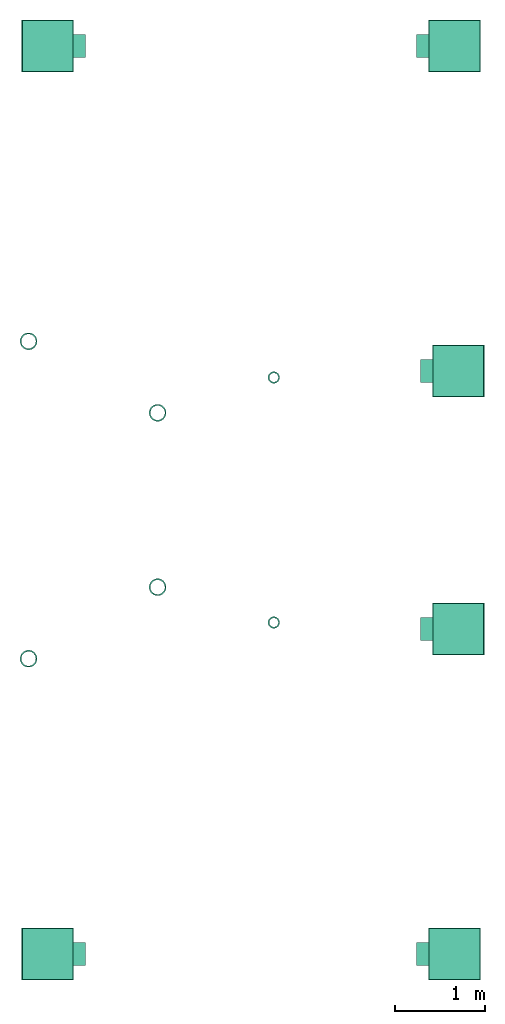
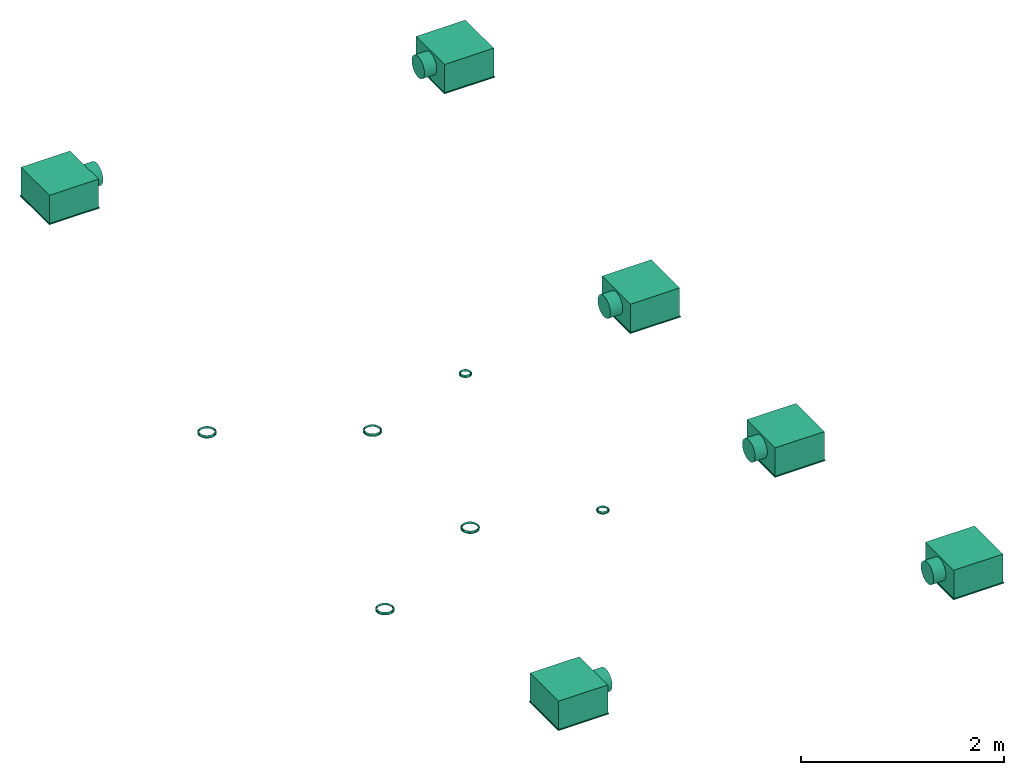
# One storey: 12 flow terminals.
"""IFC2X3 building model written with IfcOpenShell, lengths in millimetres."""

import ifcopenshell
import ifcopenshell.guid

model = None  # the IFC model being written
_history = None  # IfcOwnerHistory: only IFC2X3 demands one
_inside = {}  # id of a spatial element -> (the spatial element, [elements in it])
_under = {}  # id of a project, library or spatial element -> (it, [spatial elements below it])
_declared = {}  # id of a project -> (the project, [libraries it declares])
_typed = {}  # id of a type object -> (the type object, [elements of that type])
_made_of = {}  # id of a material, layer set ... -> (it, [elements and type objects made of it])


def new_model(schema):
    """Start an empty IFC model of exactly this schema.

    Asked for "IFC4X3", IfcOpenShell would pick the latest addendum, in which some entities
    have other attributes; the version numbers below select the first issue.
    IFC2X3 requires an IfcOwnerHistory on every rooted entity: one is made here for all.
    """
    global model, _history
    if schema == "IFC4X3":
        model = ifcopenshell.file(schema_version=(4, 3, 0, 0))
    else:
        model = ifcopenshell.file(schema=schema)
    _inside.clear()
    _under.clear()
    _declared.clear()
    _typed.clear()
    _made_of.clear()
    _history = None
    if model.schema == "IFC2X3":
        org = make("IfcOrganization", Name="unknown")
        user = make(
            "IfcPersonAndOrganization",
            ThePerson=make("IfcPerson", FamilyName="unknown"),
            TheOrganization=org,
        )
        app = make(
            "IfcApplication",
            ApplicationDeveloper=org,
            Version="unknown",
            ApplicationFullName="unknown",
            ApplicationIdentifier="unknown",
        )
        _history = make(
            "IfcOwnerHistory",
            OwningUser=user,
            OwningApplication=app,
            ChangeAction="ADDED",
            CreationDate=0,
        )
    return model


def make(cls, **values):
    """One entity of the class cls with the attributes given. An attribute that is None is left unset."""
    return model.create_entity(
        cls, **{name: value for name, value in values.items() if value is not None}
    )


def entity(cls, *values):
    """Any entity or typed value of the class cls, its attributes in the order of the schema. None: left unset."""
    e = model.create_entity(cls)
    for i, value in enumerate(values):
        if value is not None:
            e[i] = value
    return e


def rooted(cls, **values):
    """An entity with a GlobalId (a new one), such as an element, a storey or a relation."""
    return make(cls, GlobalId=ifcopenshell.guid.new(), OwnerHistory=_history, **values)


def si_unit(unit_type, name, prefix=None):
    """IfcSIUnit, for example si_unit("LENGTHUNIT", "METRE", prefix="MILLI")."""
    return make("IfcSIUnit", UnitType=unit_type, Prefix=prefix, Name=name)


def converted_unit(unit_type, name, factor, base, dimensions=None, offset=None):
    """IfcConversionBasedUnit, such as the inch: factor (a typed value) times the base unit."""
    return make(
        "IfcConversionBasedUnit"
        if offset is None
        else "IfcConversionBasedUnitWithOffset",
        ConversionOffset=offset,
        Dimensions=None
        if dimensions is None
        else entity("IfcDimensionalExponents", *dimensions),
        UnitType=unit_type,
        Name=name,
        ConversionFactor=make(
            "IfcMeasureWithUnit", ValueComponent=factor, UnitComponent=base
        ),
    )


def derived_unit(unit_type, elements):
    """IfcDerivedUnit: a product of units, each with its exponent."""
    return make(
        "IfcDerivedUnit",
        Elements=[
            make("IfcDerivedUnitElement", Unit=unit, Exponent=power)
            for unit, power in elements
        ],
        UnitType=unit_type,
    )


def assignment(units):
    """IfcUnitAssignment: the units of a project."""
    return None if units is None else make("IfcUnitAssignment", Units=units)


def point(xyz):
    """IfcCartesianPoint."""
    return None if xyz is None else make("IfcCartesianPoint", Coordinates=xyz)


def direction(xyz):
    """IfcDirection."""
    return None if xyz is None else make("IfcDirection", DirectionRatios=xyz)


def frame(location, z_axis=None, x_axis=None):
    """IfcAxis2Placement3D, a coordinate frame: its origin and axes. An axis left out is left unset."""
    return make(
        "IfcAxis2Placement3D",
        Location=point(location),
        Axis=direction(z_axis),
        RefDirection=direction(x_axis),
    )


def frame_2d(location, x_axis=None):
    """IfcAxis2Placement2D, a coordinate frame in the plane: its origin and x axis."""
    return make(
        "IfcAxis2Placement2D", Location=point(location), RefDirection=direction(x_axis)
    )


def origin():
    """The frame at (0, 0, 0) with its axes left unset."""
    return frame((0.0, 0.0, 0.0))


def origin_2d_with_axis():
    """The frame at (0, 0) in the plane with the x axis (1, 0) written out."""
    return frame_2d((0.0, 0.0), x_axis=(1.0, 0.0))


def place(relative_to, where):
    """IfcLocalPlacement: puts the frame where relative to a parent placement (None: the world)."""
    return make(
        "IfcLocalPlacement", PlacementRelTo=relative_to, RelativePlacement=where
    )


def context(
    kind, dimensions, precision=None, world=None, true_north=None, identifier=None
):
    """IfcGeometricRepresentationContext, for example the 3D "Model" context."""
    return make(
        "IfcGeometricRepresentationContext",
        ContextIdentifier=identifier,
        ContextType=kind,
        CoordinateSpaceDimension=dimensions,
        Precision=precision,
        WorldCoordinateSystem=world,
        TrueNorth=true_north,
    )


def subcontext(parent, identifier, kind, view, scale=None):
    """IfcGeometricRepresentationSubContext, for example "Body" below "Model"."""
    return make(
        "IfcGeometricRepresentationSubContext",
        ContextIdentifier=identifier,
        ContextType=kind,
        ParentContext=parent,
        TargetScale=scale,
        TargetView=view,
    )


def project(units=None, contexts=None):
    """IfcProject with its units and contexts."""
    return rooted(
        "IfcProject",
        Name="project",
        RepresentationContexts=contexts,
        UnitsInContext=assignment(units),
    )


def spatial(cls, under=None, at=None, **own):
    """A site, building, storey or space (cls), placed at a placement, below another one or the project."""
    s = rooted(cls, ObjectPlacement=at, **own)
    if under is not None:
        _under.setdefault(under.id(), (under, []))[1].append(s)
    return s


def profile(cls, at=None, kind="AREA", **sizes):
    """A parametric profile (cls). Its sizes go by their IFC names, for example OverallWidth=200.0."""
    return make(cls, ProfileType=kind, Position=at, **sizes)


def rectangle(**sizes):
    """IfcRectangleProfileDef."""
    return profile("IfcRectangleProfileDef", **sizes)


def circle(**sizes):
    """IfcCircleProfileDef."""
    return profile("IfcCircleProfileDef", **sizes)


def hollow_circle(**sizes):
    """IfcCircleHollowProfileDef."""
    return profile("IfcCircleHollowProfileDef", **sizes)


def extrude(swept, where, along, depth):
    """IfcExtrudedAreaSolid: the profile swept, set in the frame where, extruded along a direction by depth."""
    return make(
        "IfcExtrudedAreaSolid",
        SweptArea=swept,
        Position=where,
        ExtrudedDirection=direction(along),
        Depth=depth,
    )


def shape(context_of_items, identifier, shape_type, items):
    """IfcShapeRepresentation: the items that make up one representation, for example the "Body"."""
    return make(
        "IfcShapeRepresentation",
        ContextOfItems=context_of_items,
        RepresentationIdentifier=identifier,
        RepresentationType=shape_type,
        Items=items,
    )


def source(mapping_origin, context_of_items, identifier, shape_type, items):
    """IfcRepresentationMap: a shape defined once, which mapped items show again and again."""
    return make(
        "IfcRepresentationMap",
        MappingOrigin=mapping_origin,
        MappedRepresentation=shape(context_of_items, identifier, shape_type, items),
    )


def transform(
    local_origin,
    x_axis=None,
    y_axis=None,
    z_axis=None,
    scale=None,
    scale2=None,
    scale3=None,
    uniform=True,
):
    """IfcCartesianTransformationOperator3D, or its non-uniform kind. x_axis, y_axis, z_axis: its Axis1, 2, 3."""
    if uniform:
        return make(
            "IfcCartesianTransformationOperator3D",
            Axis1=direction(x_axis),
            Axis2=direction(y_axis),
            LocalOrigin=point(local_origin),
            Scale=scale,
            Axis3=direction(z_axis),
        )
    return make(
        "IfcCartesianTransformationOperator3DnonUniform",
        Axis1=direction(x_axis),
        Axis2=direction(y_axis),
        LocalOrigin=point(local_origin),
        Scale=scale,
        Axis3=direction(z_axis),
        Scale2=scale2,
        Scale3=scale3,
    )


def mapped(mapping_source, mapping_target):
    """IfcMappedItem: shows the shape of a source again, moved by a transform."""
    return make(
        "IfcMappedItem", MappingSource=mapping_source, MappingTarget=mapping_target
    )


def made_of(thing, what):
    """Note that an element or type object is made of a material, layer set ...; save() writes the relation."""
    if what is not None:
        _made_of.setdefault(what.id(), (what, []))[1].append(thing)
    return thing


def type_object(cls, material=None, **own):
    """A type object (cls), such as IfcWallType, which elements share."""
    return made_of(rooted(cls, **own), material)


def type_shapes(of_type, sources):
    """Give a type object the sources (RepresentationMaps) that its elements show as mapped items."""
    of_type.RepresentationMaps = sources


def element(
    cls,
    number,
    at=None,
    inside=None,
    cuts=None,
    type_object=None,
    material=None,
    context=None,
    identifier="Body",
    shape_type=None,
    held_by="IfcProductDefinitionShape",
    body=None,
    shapes=None,
    **own,
):
    """One element of the class cls, such as IfcWall. Its Tag is "e" and its number.

    at: its placement. inside: the storey or other place that contains it. cuts: it is an
    opening in that element (IfcRelVoidsElement). A single representation is given by context,
    identifier, shape_type and body (its items); several are given by shapes. held_by: the class
    of the entity that holds the representations. save() writes the other relations.
    """
    e = rooted(cls, Tag="e%d" % number, ObjectPlacement=at, **own)
    if body is not None:
        shapes = [shape(context, identifier, shape_type, body)]
    if shapes is not None:
        e.Representation = make(held_by, Representations=shapes)
    if inside is not None:
        _inside.setdefault(inside.id(), (inside, []))[1].append(e)
    if cuts is not None:
        rooted(
            "IfcRelVoidsElement", RelatingBuildingElement=cuts, RelatedOpeningElement=e
        )
    if type_object is not None:
        _typed.setdefault(type_object.id(), (type_object, []))[1].append(e)
    return made_of(e, material)


def aggregate(whole, parts):
    """IfcRelAggregates: a whole, such as a stair, and the parts it consists of."""
    return rooted("IfcRelAggregates", RelatingObject=whole, RelatedObjects=parts)


def save(model, path):
    """Write the relations noted so far, then the file.

    IfcRelAggregates (storeys below a building ...), IfcRelContainedInSpatialStructure (elements
    in a storey), IfcRelDefinesByType, IfcRelAssociatesMaterial and IfcRelDeclares: one each for
    every whole, place, type object, material and project.
    """
    for whole, parts in _under.values():
        aggregate(whole, parts)
    for where, things in _inside.values():
        rooted(
            "IfcRelContainedInSpatialStructure",
            RelatedElements=things,
            RelatingStructure=where,
        )
    for kind, things in _typed.values():
        rooted("IfcRelDefinesByType", RelatedObjects=things, RelatingType=kind)
    for what, things in _made_of.values():
        rooted("IfcRelAssociatesMaterial", RelatedObjects=things, RelatingMaterial=what)
    for by, libraries in _declared.values():
        rooted("IfcRelDeclares", RelatingContext=by, RelatedDefinitions=libraries)
    model.write(path)


model = new_model("IFC2X3")

# Units and contexts
model_context = context("Model", 3, precision=0.01, world=origin(), true_north=direction((6.12303176911189e-17, 1.0)))
body_context = subcontext(model_context, "Body", "Model", "MODEL_VIEW")
ifc_project = project(units=[si_unit("LENGTHUNIT", "METRE", prefix="MILLI"), si_unit("AREAUNIT", "SQUARE_METRE"), si_unit("VOLUMEUNIT", "CUBIC_METRE"), converted_unit("PLANEANGLEUNIT", "DEGREE", entity("IfcRatioMeasure", 0.0174532925199433), si_unit("PLANEANGLEUNIT", "RADIAN"), dimensions=[0, 0, 0, 0, 0, 0, 0]), si_unit("MASSUNIT", "GRAM", prefix="KILO"), derived_unit("MASSDENSITYUNIT", [(si_unit("MASSUNIT", "GRAM", prefix="KILO"), 1), (si_unit("LENGTHUNIT", "METRE"), -3)]), si_unit("TIMEUNIT", "SECOND"), si_unit("FREQUENCYUNIT", "HERTZ"), si_unit("THERMODYNAMICTEMPERATUREUNIT", "DEGREE_CELSIUS"), derived_unit("THERMALTRANSMITTANCEUNIT", [(si_unit("MASSUNIT", "GRAM", prefix="KILO"), 1), (si_unit("THERMODYNAMICTEMPERATUREUNIT", "KELVIN"), -1), (si_unit("TIMEUNIT", "SECOND"), -3)]), derived_unit("VOLUMETRICFLOWRATEUNIT", [(si_unit("LENGTHUNIT", "METRE"), 3), (si_unit("TIMEUNIT", "SECOND"), -1)]), si_unit("ELECTRICCURRENTUNIT", "AMPERE"), si_unit("ELECTRICVOLTAGEUNIT", "VOLT"), si_unit("POWERUNIT", "WATT"), si_unit("FORCEUNIT", "NEWTON", prefix="KILO"), si_unit("ILLUMINANCEUNIT", "LUX"), si_unit("LUMINOUSFLUXUNIT", "LUMEN"), si_unit("LUMINOUSINTENSITYUNIT", "CANDELA"), derived_unit("USERDEFINED", [(si_unit("MASSUNIT", "GRAM", prefix="KILO"), -1), (si_unit("LENGTHUNIT", "METRE"), -2), (si_unit("TIMEUNIT", "SECOND"), 3), (si_unit("LUMINOUSFLUXUNIT", "LUMEN"), 1)]), derived_unit("LINEARVELOCITYUNIT", [(si_unit("LENGTHUNIT", "METRE"), 1), (si_unit("TIMEUNIT", "SECOND"), -1)]), si_unit("PRESSUREUNIT", "PASCAL"), derived_unit("USERDEFINED", [(si_unit("LENGTHUNIT", "METRE"), -2), (si_unit("MASSUNIT", "GRAM", prefix="KILO"), 1), (si_unit("TIMEUNIT", "SECOND"), -2)])], contexts=[model_context])

# Site, building, storey
site_placement = place(None, origin())
site = spatial("IfcSite", under=ifc_project, at=site_placement, CompositionType="ELEMENT")
building_placement = place(site_placement, origin())
building = spatial("IfcBuilding", under=site, at=building_placement, CompositionType="ELEMENT")
storey_placement = place(building_placement, frame((0.0, 0.0, 4000.0)))
storey = spatial("IfcBuildingStorey", under=building, at=storey_placement, Name="01 Level", CompositionType="ELEMENT", Elevation=4000.0)

# Flow terminals
air_terminal_type_1 = type_object("IfcAirTerminalType", Name="KU 160", PredefinedType="NOTDEFINED")
shared_shape_1 = source(origin(), body_context, "Body", "SweptSolid", [
    extrude(hollow_circle(Radius=94.9999999999999, WallThickness=15.0, at=frame_2d((0.0, -1.53476734571096e-13), x_axis=(1.0, 0.0))), frame((12.9, 0.0, 0.0), z_axis=(1.0, 0.0, 0.0), x_axis=(0.0, 1.0, 0.0)), (0.0, 0.0, 1.0), 0.200000000000001),
    extrude(hollow_circle(Radius=79.9999999999999, WallThickness=0.200000000000003, at=frame_2d((2.53588544712624e-13, 0.0), x_axis=(1.0, 0.0))), frame((-13.0, 0.0, 0.0), z_axis=(1.0, 0.0, 0.0), x_axis=(0.0, 0.0, 1.0)), (0.0, 0.0, 1.0), 26.0),
    extrude(hollow_circle(Radius=94.9999999999999, WallThickness=0.200000000000017, at=frame_2d((0.0, -1.53476734571096e-13), x_axis=(1.0, 0.0))), frame((0.0, 0.0, 0.0), z_axis=(1.0, 0.0, 0.0), x_axis=(0.0, 1.0, 0.0)), (0.0, 0.0, 1.0), 13.0),
])
type_shapes(air_terminal_type_1, [shared_shape_1])
for number, where, z_axis, x_axis, name in (
    (1, (22191.748982204, -70586.2395851399, 2600.0), (1.0, 0.0, 0.0), (0.0, 0.0, -1.0), "KU-0001:KU 160"),
    (2, (23618.7604148601, -69795.234231492, 2600.0), (1.0, 0.0, 0.0), (0.0, 0.0, -1.0), "KU-0001:KU 160"),
):
    element("IfcFlowTerminal", number, at=place(storey_placement, frame(where, z_axis=z_axis, x_axis=x_axis)), inside=storey, type_object=air_terminal_type_1, Name=name, ObjectType="KU-0001:KU 160", context=body_context, shape_type="MappedRepresentation", body=[
        mapped(shared_shape_1, transform((0.0, 0.0, 0.0), scale=1.0)),
    ])
air_terminal_type_2 = type_object("IfcAirTerminalType", Name="KU 100", PredefinedType="NOTDEFINED")
shared_shape_2 = source(origin(), body_context, "Body", "SweptSolid", [
    extrude(hollow_circle(Radius=64.9999999999999, WallThickness=15.0, at=frame_2d((0.0, -1.05010397338118e-13), x_axis=(1.0, 0.0))), frame((12.9, 0.0, 0.0), z_axis=(1.0, 0.0, 0.0), x_axis=(0.0, 1.0, 0.0)), (0.0, 0.0, 1.0), 0.200000000000001),
    extrude(hollow_circle(Radius=50.0, WallThickness=0.199999999999996, at=frame_2d((1.5849284044539e-13, 0.0), x_axis=(1.0, 0.0))), frame((-13.0, 0.0, 0.0), z_axis=(1.0, 0.0, 0.0), x_axis=(0.0, 0.0, 1.0)), (0.0, 0.0, 1.0), 26.0),
    extrude(hollow_circle(Radius=64.9999999999999, WallThickness=0.199999999999989, at=frame_2d((0.0, -1.05010397338118e-13), x_axis=(1.0, 0.0))), frame((0.0, 0.0, 0.0), z_axis=(1.0, 0.0, 0.0), x_axis=(0.0, 1.0, 0.0)), (0.0, 0.0, 1.0), 13.0),
])
type_shapes(air_terminal_type_2, [shared_shape_2])
flow_terminal_1_placement = place(storey_placement, frame((24903.4900708518, -70185.935612491, 2600.0), z_axis=(1.0, 0.0, 0.0), x_axis=(0.0, 0.0, -1.0)))
element("IfcFlowTerminal", 3, at=flow_terminal_1_placement, inside=storey, type_object=air_terminal_type_2, Name="KU-0001:KU 100", ObjectType="KU-0001:KU 100", context=body_context, shape_type="MappedRepresentation", body=[
    mapped(shared_shape_2, transform((0.0, 0.0, 0.0), scale=1.0)),
])
air_terminal_type_3 = type_object("IfcAirTerminalType", PredefinedType="NOTDEFINED")
shared_shape_3 = source(origin(), body_context, "Body", "SweptSolid", [
    extrude(rectangle(XDim=575.0, YDim=575.0, at=origin_2d_with_axis()), frame((0.0, 0.0, -10.0), z_axis=(0.0, 0.0, 1.0), x_axis=(-1.0, 0.0, 0.0)), (0.0, 0.0, 1.0), 10.0),
    extrude(rectangle(XDim=560.0, YDim=560.0, at=origin_2d_with_axis()), frame((0.0, 0.0, 0.0), z_axis=(0.0, 0.0, 1.0), x_axis=(-1.0, 0.0, 0.0)), (0.0, 0.0, 1.0), 340.0),
    extrude(circle(Radius=125.0, at=frame_2d((-4.22656881875445e-30, 8.12150346973795e-13), x_axis=(1.0, 0.0))), frame((-420.0, 0.0, 190.0), z_axis=(1.0, 0.0, 0.0), x_axis=(0.0, 1.0, 0.0)), (0.0, 0.0, 1.0), 140.0),
])
type_shapes(air_terminal_type_3, [shared_shape_3])
flow_terminal_2_placement = place(storey_placement, frame((26901.3414033464, -73851.9018959535, 3320.0)))
element("IfcFlowTerminal", 4, at=flow_terminal_2_placement, inside=storey, type_object=air_terminal_type_3, context=body_context, shape_type="MappedRepresentation", body=[
    mapped(shared_shape_3, transform((0.0, 0.0, 0.0), scale=1.0)),
])
flow_terminal_3_placement = place(storey_placement, frame((22402.2515072766, -73851.9018959535, 3320.0), z_axis=(0.0, 0.0, 1.0), x_axis=(-1.0, 0.0, 0.0)))
element("IfcFlowTerminal", 5, at=flow_terminal_3_placement, inside=storey, type_object=air_terminal_type_3, context=body_context, shape_type="MappedRepresentation", body=[
    mapped(shared_shape_3, transform((0.0, 0.0, 0.0), scale=1.0)),
])
air_terminal_type_4 = type_object("IfcAirTerminalType", PredefinedType="NOTDEFINED")
shared_shape_4 = source(origin(), body_context, "Body", "SweptSolid", [
    extrude(rectangle(XDim=575.0, YDim=575.0, at=origin_2d_with_axis()), frame((0.0, 0.0, -10.0), z_axis=(0.0, 0.0, 1.0), x_axis=(-1.0, 0.0, 0.0)), (0.0, 0.0, 1.0), 10.0),
    extrude(rectangle(XDim=560.0, YDim=560.0, at=origin_2d_with_axis()), frame((0.0, 0.0, 0.0), z_axis=(0.0, 0.0, 1.0), x_axis=(-1.0, 0.0, 0.0)), (0.0, 0.0, 1.0), 340.0),
    extrude(circle(Radius=125.0, at=frame_2d((-4.22656881875445e-30, 8.12150346973795e-13), x_axis=(1.0, 0.0))), frame((-420.0, 0.0, 190.0), z_axis=(1.0, 0.0, 0.0), x_axis=(0.0, 1.0, 0.0)), (0.0, 0.0, 1.0), 140.0),
])
type_shapes(air_terminal_type_4, [shared_shape_4])
flow_terminal_4_placement = place(storey_placement, frame((26943.4900708518, -70257.4616421941, 2600.0)))
element("IfcFlowTerminal", 6, at=flow_terminal_4_placement, inside=storey, type_object=air_terminal_type_4, context=body_context, shape_type="MappedRepresentation", body=[
    mapped(shared_shape_4, transform((0.0, 0.0, 0.0), scale=1.0)),
])
air_terminal_type_5 = type_object("IfcAirTerminalType", Name="KU 160", PredefinedType="NOTDEFINED")
shared_shape_5 = source(origin(), body_context, "Body", "SweptSolid", [
    extrude(hollow_circle(Radius=94.9999999999999, WallThickness=15.0, at=frame_2d((0.0, -4.27701821653509e-13), x_axis=(1.0, 0.0))), frame((12.9, 0.0, 0.0), z_axis=(1.0, 0.0, 0.0), x_axis=(0.0, -1.0, 0.0)), (0.0, 0.0, 1.0), 0.200000000000001),
    extrude(hollow_circle(Radius=79.9999999999999, WallThickness=0.200000000000003, at=frame_2d((2.53588544712624e-13, 1.60767875023667e-27), x_axis=(1.0, 0.0))), frame((-13.0, 0.0, 0.0), z_axis=(1.0, 0.0, 0.0), x_axis=(0.0, 0.0, -1.0)), (0.0, 0.0, 1.0), 26.0),
    extrude(hollow_circle(Radius=94.9999999999999, WallThickness=0.200000000000017, at=frame_2d((0.0, -4.27701821653509e-13), x_axis=(1.0, 0.0))), frame((0.0, 0.0, 0.0), z_axis=(1.0, 0.0, 0.0), x_axis=(0.0, -1.0, 0.0)), (0.0, 0.0, 1.0), 13.0),
])
type_shapes(air_terminal_type_5, [shared_shape_5])
for number, where, z_axis, x_axis, name in (
    (7, (22191.748982204, -67076.2395851399, 2600.0), (1.0, 0.0, 0.0), (0.0, 0.0, -1.0), "KU-0001:KU 160"),
    (8, (23618.7604148601, -67867.2449387878, 2600.0), (1.0, 0.0, 0.0), (0.0, 0.0, -1.0), "KU-0001:KU 160"),
):
    element("IfcFlowTerminal", number, at=place(storey_placement, frame(where, z_axis=z_axis, x_axis=x_axis)), inside=storey, type_object=air_terminal_type_5, Name=name, ObjectType="KU-0001:KU 160", context=body_context, shape_type="MappedRepresentation", body=[
        mapped(shared_shape_5, transform((0.0, 0.0, 0.0), scale=1.0)),
    ])
air_terminal_type_6 = type_object("IfcAirTerminalType", Name="KU 100", PredefinedType="NOTDEFINED")
shared_shape_6 = source(origin(), body_context, "Body", "SweptSolid", [
    extrude(hollow_circle(Radius=64.9999999999999, WallThickness=15.0, at=frame_2d((0.0, -2.92638088499769e-13), x_axis=(1.0, 0.0))), frame((12.9, 0.0, 0.0), z_axis=(1.0, 0.0, 0.0), x_axis=(0.0, -1.0, 0.0)), (0.0, 0.0, 1.0), 0.200000000000001),
    extrude(hollow_circle(Radius=50.0, WallThickness=0.199999999999996, at=frame_2d((1.5849284044539e-13, 1.00479921889792e-27), x_axis=(1.0, 0.0))), frame((-13.0, 0.0, 0.0), z_axis=(1.0, 0.0, 0.0), x_axis=(0.0, 0.0, -1.0)), (0.0, 0.0, 1.0), 26.0),
    extrude(hollow_circle(Radius=64.9999999999999, WallThickness=0.199999999999989, at=frame_2d((0.0, -2.92638088499769e-13), x_axis=(1.0, 0.0))), frame((0.0, 0.0, 0.0), z_axis=(1.0, 0.0, 0.0), x_axis=(0.0, -1.0, 0.0)), (0.0, 0.0, 1.0), 13.0),
])
type_shapes(air_terminal_type_6, [shared_shape_6])
flow_terminal_5_placement = place(storey_placement, frame((24903.4900708518, -67476.5435577888, 2600.0), z_axis=(1.0, 0.0, 0.0), x_axis=(0.0, 0.0, -1.0)))
element("IfcFlowTerminal", 9, at=flow_terminal_5_placement, inside=storey, type_object=air_terminal_type_6, Name="KU-0001:KU 100", ObjectType="KU-0001:KU 100", context=body_context, shape_type="MappedRepresentation", body=[
    mapped(shared_shape_6, transform((0.0, 0.0, 0.0), scale=1.0)),
])
air_terminal_type_7 = type_object("IfcAirTerminalType", PredefinedType="NOTDEFINED")
shared_shape_7 = source(origin(), body_context, "Body", "SweptSolid", [
    extrude(rectangle(XDim=575.0, YDim=575.0, at=origin_2d_with_axis()), frame((0.0, 0.0, -10.0), z_axis=(0.0, 0.0, 1.0), x_axis=(0.0, 1.0, 0.0)), (0.0, 0.0, 1.0), 10.0),
    extrude(rectangle(XDim=560.0, YDim=560.0, at=origin_2d_with_axis()), frame((0.0, 0.0, 0.0), z_axis=(0.0, 0.0, 1.0), x_axis=(0.0, 1.0, 0.0)), (0.0, 0.0, 1.0), 340.0),
    extrude(circle(Radius=125.0, at=frame_2d((6.49488288124937e-16, 1.35358391162299e-13), x_axis=(1.0, 0.0))), frame((-420.0, 0.0, 190.0), z_axis=(1.0, 0.0, 0.0), x_axis=(0.0, -1.0, 0.0)), (0.0, 0.0, 1.0), 140.0),
])
type_shapes(air_terminal_type_7, [shared_shape_7])
flow_terminal_6_placement = place(storey_placement, frame((26901.3414033465, -63810.5772743263, 3320.0)))
element("IfcFlowTerminal", 10, at=flow_terminal_6_placement, inside=storey, type_object=air_terminal_type_7, context=body_context, shape_type="MappedRepresentation", body=[
    mapped(shared_shape_7, transform((0.0, 0.0, 0.0), scale=1.0)),
])
flow_terminal_7_placement = place(storey_placement, frame((22402.2515072766, -63810.5772743263, 3320.0), z_axis=(0.0, 0.0, 1.0), x_axis=(-1.0, 0.0, 0.0)))
element("IfcFlowTerminal", 11, at=flow_terminal_7_placement, inside=storey, type_object=air_terminal_type_7, context=body_context, shape_type="MappedRepresentation", body=[
    mapped(shared_shape_7, transform((0.0, 0.0, 0.0), scale=1.0)),
])
air_terminal_type_8 = type_object("IfcAirTerminalType", PredefinedType="NOTDEFINED")
shared_shape_8 = source(origin(), body_context, "Body", "SweptSolid", [
    extrude(rectangle(XDim=575.0, YDim=575.0, at=origin_2d_with_axis()), frame((0.0, 0.0, -10.0), z_axis=(0.0, 0.0, 1.0), x_axis=(0.0, 1.0, 0.0)), (0.0, 0.0, 1.0), 10.0),
    extrude(rectangle(XDim=560.0, YDim=560.0, at=origin_2d_with_axis()), frame((0.0, 0.0, 0.0), z_axis=(0.0, 0.0, 1.0), x_axis=(0.0, 1.0, 0.0)), (0.0, 0.0, 1.0), 340.0),
    extrude(circle(Radius=125.0, at=frame_2d((6.49488288124937e-16, 1.35358391162299e-13), x_axis=(1.0, 0.0))), frame((-420.0, 0.0, 190.0), z_axis=(1.0, 0.0, 0.0), x_axis=(0.0, -1.0, 0.0)), (0.0, 0.0, 1.0), 140.0),
])
type_shapes(air_terminal_type_8, [shared_shape_8])
flow_terminal_8_placement = place(storey_placement, frame((26943.4900708518, -67405.0175280858, 2600.0)))
element("IfcFlowTerminal", 12, at=flow_terminal_8_placement, inside=storey, type_object=air_terminal_type_8, context=body_context, shape_type="MappedRepresentation", body=[
    mapped(shared_shape_8, transform((0.0, 0.0, 0.0), scale=1.0)),
])

save(model, "model.ifc")
